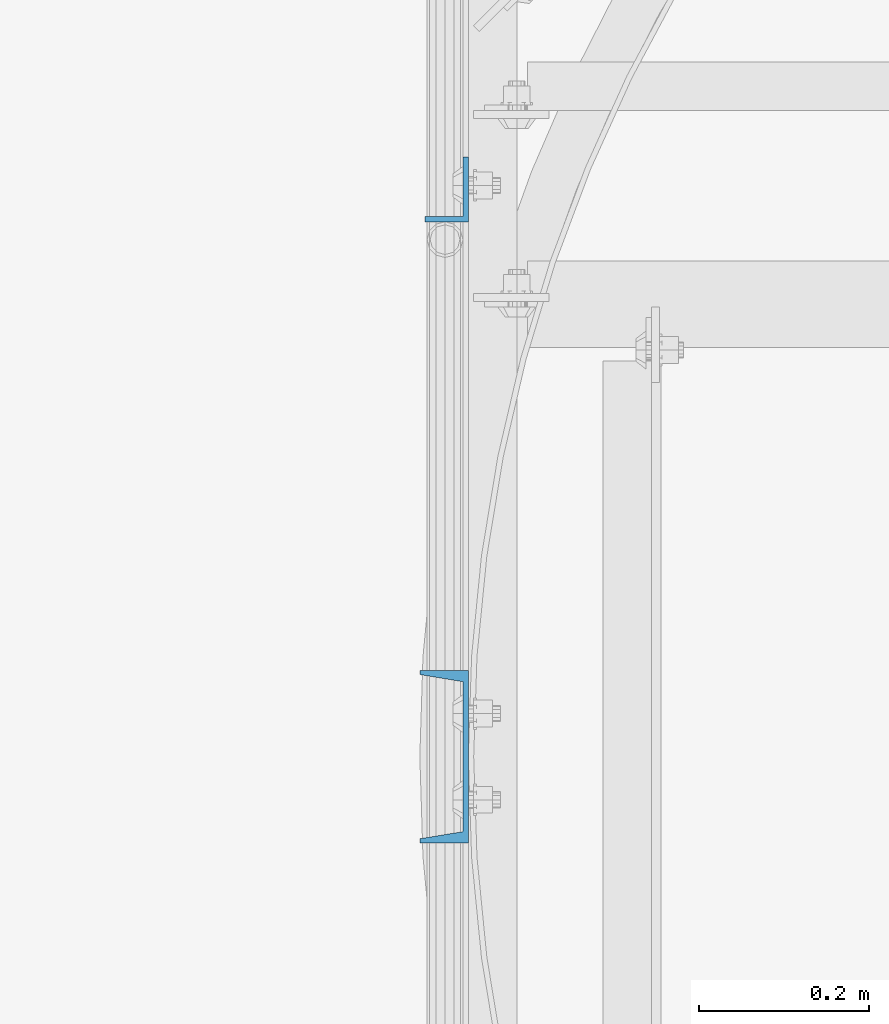
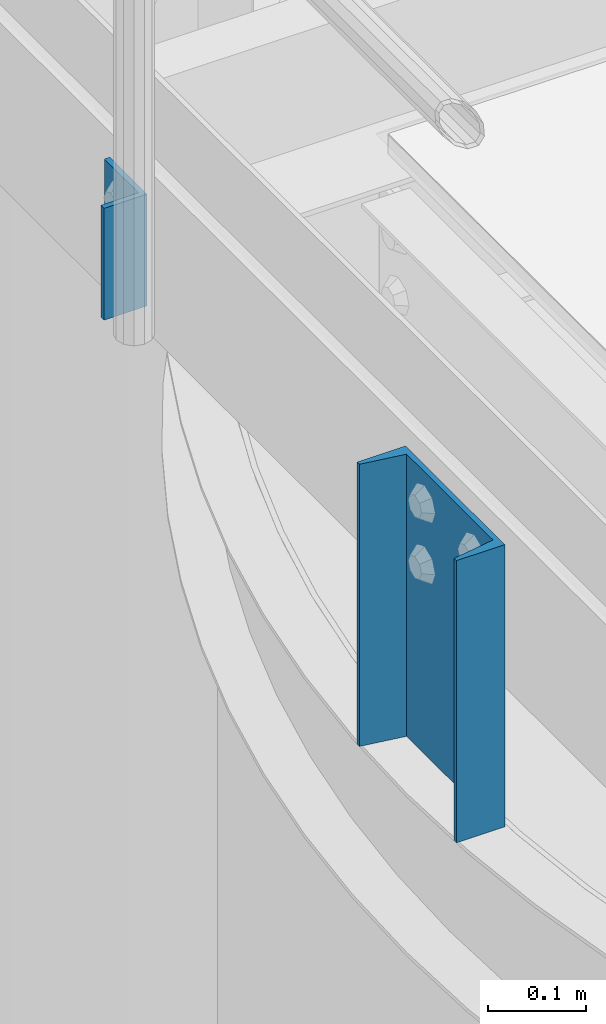
# One storey, part 784 of 1876: 2 columns, 2 elements without a shape of their own.
"""IFC2X3 building model written with IfcOpenShell, lengths in millimetres."""

import ifcopenshell
import ifcopenshell.guid

model = None  # the IFC model being written
_history = None  # IfcOwnerHistory: only IFC2X3 demands one
_inside = {}  # id of a spatial element -> (the spatial element, [elements in it])
_under = {}  # id of a project, library or spatial element -> (it, [spatial elements below it])
_declared = {}  # id of a project -> (the project, [libraries it declares])
_typed = {}  # id of a type object -> (the type object, [elements of that type])
_made_of = {}  # id of a material, layer set ... -> (it, [elements and type objects made of it])


def new_model(schema):
    """Start an empty IFC model of exactly this schema.

    Asked for "IFC4X3", IfcOpenShell would pick the latest addendum, in which some entities
    have other attributes; the version numbers below select the first issue.
    IFC2X3 requires an IfcOwnerHistory on every rooted entity: one is made here for all.
    """
    global model, _history
    if schema == "IFC4X3":
        model = ifcopenshell.file(schema_version=(4, 3, 0, 0))
    else:
        model = ifcopenshell.file(schema=schema)
    _inside.clear()
    _under.clear()
    _declared.clear()
    _typed.clear()
    _made_of.clear()
    _history = None
    if model.schema == "IFC2X3":
        org = make("IfcOrganization", Name="unknown")
        user = make(
            "IfcPersonAndOrganization",
            ThePerson=make("IfcPerson", FamilyName="unknown"),
            TheOrganization=org,
        )
        app = make(
            "IfcApplication",
            ApplicationDeveloper=org,
            Version="unknown",
            ApplicationFullName="unknown",
            ApplicationIdentifier="unknown",
        )
        _history = make(
            "IfcOwnerHistory",
            OwningUser=user,
            OwningApplication=app,
            ChangeAction="ADDED",
            CreationDate=0,
        )
    return model


def make(cls, **values):
    """One entity of the class cls with the attributes given. An attribute that is None is left unset."""
    return model.create_entity(
        cls, **{name: value for name, value in values.items() if value is not None}
    )


def rooted(cls, **values):
    """An entity with a GlobalId (a new one), such as an element, a storey or a relation."""
    return make(cls, GlobalId=ifcopenshell.guid.new(), OwnerHistory=_history, **values)


def si_unit(unit_type, name, prefix=None):
    """IfcSIUnit, for example si_unit("LENGTHUNIT", "METRE", prefix="MILLI")."""
    return make("IfcSIUnit", UnitType=unit_type, Prefix=prefix, Name=name)


def assignment(units):
    """IfcUnitAssignment: the units of a project."""
    return None if units is None else make("IfcUnitAssignment", Units=units)


def point(xyz):
    """IfcCartesianPoint."""
    return None if xyz is None else make("IfcCartesianPoint", Coordinates=xyz)


def direction(xyz):
    """IfcDirection."""
    return None if xyz is None else make("IfcDirection", DirectionRatios=xyz)


def frame(location, z_axis=None, x_axis=None):
    """IfcAxis2Placement3D, a coordinate frame: its origin and axes. An axis left out is left unset."""
    return make(
        "IfcAxis2Placement3D",
        Location=point(location),
        Axis=direction(z_axis),
        RefDirection=direction(x_axis),
    )


def origin_with_axes():
    """The frame at (0, 0, 0) with the z axis (0, 0, 1) and the x axis (1, 0, 0) written out."""
    return frame((0.0, 0.0, 0.0), z_axis=(0.0, 0.0, 1.0), x_axis=(1.0, 0.0, 0.0))


def place(relative_to, where):
    """IfcLocalPlacement: puts the frame where relative to a parent placement (None: the world)."""
    return make(
        "IfcLocalPlacement", PlacementRelTo=relative_to, RelativePlacement=where
    )


def context(
    kind, dimensions, precision=None, world=None, true_north=None, identifier=None
):
    """IfcGeometricRepresentationContext, for example the 3D "Model" context."""
    return make(
        "IfcGeometricRepresentationContext",
        ContextIdentifier=identifier,
        ContextType=kind,
        CoordinateSpaceDimension=dimensions,
        Precision=precision,
        WorldCoordinateSystem=world,
        TrueNorth=true_north,
    )


def subcontext(parent, identifier, kind, view, scale=None):
    """IfcGeometricRepresentationSubContext, for example "Body" below "Model"."""
    return make(
        "IfcGeometricRepresentationSubContext",
        ContextIdentifier=identifier,
        ContextType=kind,
        ParentContext=parent,
        TargetScale=scale,
        TargetView=view,
    )


def project(units=None, contexts=None):
    """IfcProject with its units and contexts."""
    return rooted(
        "IfcProject",
        Name="project",
        RepresentationContexts=contexts,
        UnitsInContext=assignment(units),
    )


def spatial(cls, under=None, at=None, **own):
    """A site, building, storey or space (cls), placed at a placement, below another one or the project."""
    s = rooted(cls, ObjectPlacement=at, **own)
    if under is not None:
        _under.setdefault(under.id(), (under, []))[1].append(s)
    return s


def faces_of(points, faces, orient=None, outer=None):
    """IfcFace entities. A face is a list of loops; a loop is a list of indices into points, from 0.

    orient and outer hold one flag for each loop. By default every Orientation is true, the
    first loop of a face is its IfcFaceOuterBound and the others are IfcFaceBound.
    """
    made = []
    for i, loops in enumerate(faces):
        bounds = []
        for j, loop in enumerate(loops):
            is_outer = j == 0 if outer is None else outer[i][j]
            bounds.append(
                make(
                    "IfcFaceOuterBound" if is_outer else "IfcFaceBound",
                    Bound=make("IfcPolyLoop", Polygon=[points[k] for k in loop]),
                    Orientation=True if orient is None else orient[i][j],
                )
            )
        made.append(make("IfcFace", Bounds=bounds))
    return made


def faceted_brep(points, faces, orient=None, outer=None, voids=None):
    """IfcFacetedBrep: a solid bounded by flat faces; with voids (closed shells), ...WithVoids."""
    shared = [point(p) for p in points]
    hull = make("IfcClosedShell", CfsFaces=faces_of(shared, faces, orient, outer))
    if voids is None:
        return make("IfcFacetedBrep", Outer=hull)
    return make(
        "IfcFacetedBrepWithVoids",
        Outer=hull,
        Voids=[
            make(cls, CfsFaces=faces_of(shared, fs, o, b)) for cls, fs, o, b in voids
        ],
    )


def shape(context_of_items, identifier, shape_type, items):
    """IfcShapeRepresentation: the items that make up one representation, for example the "Body"."""
    return make(
        "IfcShapeRepresentation",
        ContextOfItems=context_of_items,
        RepresentationIdentifier=identifier,
        RepresentationType=shape_type,
        Items=items,
    )


def material(Name=None, Category=None):
    """IfcMaterial."""
    return make("IfcMaterial", Name=Name, Category=Category)


def made_of(thing, what):
    """Note that an element or type object is made of a material, layer set ...; save() writes the relation."""
    if what is not None:
        _made_of.setdefault(what.id(), (what, []))[1].append(thing)
    return thing


def type_object(cls, material=None, **own):
    """A type object (cls), such as IfcWallType, which elements share."""
    return made_of(rooted(cls, **own), material)


def element(
    cls,
    number,
    at=None,
    inside=None,
    cuts=None,
    type_object=None,
    material=None,
    context=None,
    identifier="Body",
    shape_type=None,
    held_by="IfcProductDefinitionShape",
    body=None,
    shapes=None,
    **own,
):
    """One element of the class cls, such as IfcWall. Its Tag is "e" and its number.

    at: its placement. inside: the storey or other place that contains it. cuts: it is an
    opening in that element (IfcRelVoidsElement). A single representation is given by context,
    identifier, shape_type and body (its items); several are given by shapes. held_by: the class
    of the entity that holds the representations. save() writes the other relations.
    """
    e = rooted(cls, Tag="e%d" % number, ObjectPlacement=at, **own)
    if body is not None:
        shapes = [shape(context, identifier, shape_type, body)]
    if shapes is not None:
        e.Representation = make(held_by, Representations=shapes)
    if inside is not None:
        _inside.setdefault(inside.id(), (inside, []))[1].append(e)
    if cuts is not None:
        rooted(
            "IfcRelVoidsElement", RelatingBuildingElement=cuts, RelatedOpeningElement=e
        )
    if type_object is not None:
        _typed.setdefault(type_object.id(), (type_object, []))[1].append(e)
    return made_of(e, material)


def aggregate(whole, parts):
    """IfcRelAggregates: a whole, such as a stair, and the parts it consists of."""
    return rooted("IfcRelAggregates", RelatingObject=whole, RelatedObjects=parts)


def save(model, path):
    """Write the relations noted so far, then the file.

    IfcRelAggregates (storeys below a building ...), IfcRelContainedInSpatialStructure (elements
    in a storey), IfcRelDefinesByType, IfcRelAssociatesMaterial and IfcRelDeclares: one each for
    every whole, place, type object, material and project.
    """
    for whole, parts in _under.values():
        aggregate(whole, parts)
    for where, things in _inside.values():
        rooted(
            "IfcRelContainedInSpatialStructure",
            RelatedElements=things,
            RelatingStructure=where,
        )
    for kind, things in _typed.values():
        rooted("IfcRelDefinesByType", RelatedObjects=things, RelatingType=kind)
    for what, things in _made_of.values():
        rooted("IfcRelAssociatesMaterial", RelatedObjects=things, RelatingMaterial=what)
    for by, libraries in _declared.values():
        rooted("IfcRelDeclares", RelatingContext=by, RelatedDefinitions=libraries)
    model.write(path)


model = new_model("IFC2X3")

# Units and contexts
model_context = context("Model", 3, precision=1e-05, world=origin_with_axes())
body_context = subcontext(model_context, "Body", "Model", "MODEL_VIEW")
ifc_project = project(units=[si_unit("LENGTHUNIT", "METRE", prefix="MILLI"), si_unit("AREAUNIT", "SQUARE_METRE"), si_unit("VOLUMEUNIT", "CUBIC_METRE"), si_unit("MASSUNIT", "GRAM", prefix="KILO"), si_unit("TIMEUNIT", "SECOND"), si_unit("PLANEANGLEUNIT", "RADIAN"), si_unit("SOLIDANGLEUNIT", "STERADIAN"), si_unit("THERMODYNAMICTEMPERATUREUNIT", "DEGREE_CELSIUS"), si_unit("LUMINOUSINTENSITYUNIT", "LUMEN")], contexts=[model_context])

# Site, building, storey
site_placement = place(None, origin_with_axes())
site = spatial("IfcSite", under=ifc_project, at=site_placement, CompositionType="ELEMENT")
building_placement = place(site_placement, origin_with_axes())
building = spatial("IfcBuilding", under=site, at=building_placement, Name="Undefined", CompositionType="ELEMENT")
storey_placement = place(building_placement, origin_with_axes())
storey = spatial("IfcBuildingStorey", under=building, at=storey_placement, Name="Undefined", CompositionType="ELEMENT", Elevation=0.0)

# Assembly, column
assembly_1_placement = place(storey_placement, origin_with_axes())
assembly_1 = element("IfcElementAssembly", 1, at=assembly_1_placement, inside=storey, Name="HANDRAIL", AssemblyPlace="NOTDEFINED", PredefinedType="RIGID_FRAME")
ifc_material = material(Name="STEEL/A36")
column_type_1 = type_object("IfcColumnType", Name="L3X2X1/4", PredefinedType="NOTDEFINED")
column_1_placement = place(assembly_1_placement, frame((3340.10143150122, -12920.1824042969, 7826.375), z_axis=(0.0, 1.0, 0.0), x_axis=(0.0, 0.0, 1.0)))
column_1 = element("IfcColumn", 2, at=column_1_placement, type_object=column_type_1, material=ifc_material, Name="ANGLE", ObjectType="L3X2X1/4", context=body_context, shape_type="Brep", body=[
    faceted_brep([(0.0, 25.3999999999996, -38.1000000000004), (0.0, 25.3999999999996, 38.1000000000004), (139.7, 25.3999999999996, 38.1000000000004), (139.7, 25.3999999999996, -38.1000000000004), (0.0, 19.0500000000002, 38.1000000000004), (139.7, 19.0500000000002, 38.1000000000004), (0.0, 19.0500000000002, -31.75), (139.7, 19.0500000000002, -31.75), (0.0, -25.3999999999996, -31.75), (139.7, -25.3999999999996, -31.75), (0.0, -25.3999999999996, -38.1000000000004), (139.7, -25.3999999999996, -38.1000000000004)], [[[0, 1, 2, 3]], [[1, 4, 5, 2]], [[4, 6, 7, 5]], [[6, 8, 9, 7]], [[8, 10, 11, 9]], [[10, 0, 3, 11]], [[5, 7, 9, 11, 3, 2]], [[10, 8, 6, 4, 1, 0]]]),
])
aggregate(assembly_1, [column_1])

assembly_2_placement = place(storey_placement, origin_with_axes())
assembly_2 = element("IfcElementAssembly", 3, at=assembly_2_placement, inside=storey, Name="BEAM", AssemblyPlace="NOTDEFINED", PredefinedType="RIGID_FRAME")
column_type_2 = type_object("IfcColumnType", Name="C8X11.5", PredefinedType="NOTDEFINED")
column_2_placement = place(assembly_2_placement, frame((3336.92643150122, -13588.9644287103, 7620.01566278096), z_axis=(0.0, 1.0, 0.0), x_axis=(0.0, 0.0, 1.0)))
column_2 = element("IfcColumn", 4, at=column_2_placement, type_object=column_type_2, material=ifc_material, Name="BEAM", ObjectType="C8X11.5", context=body_context, shape_type="Brep", body=[
    faceted_brep([(0.0, 28.5749999999998, -101.6), (0.0, 28.5749999999998, 101.6), (352.425, 28.5749999999998, 101.6), (352.425, 28.5749999999998, -101.6), (0.0, -28.5749999999998, 101.6), (352.425, -28.5749999999998, 101.6), (0.0, -28.5749999999998, 96.8355950000005), (352.425, -28.5749999999998, 96.8355950000005), (0.0, 22.2250000000004, 88.3723150000005), (352.425, 22.2250000000004, 88.3723150000005), (0.0, 22.2250000000004, -88.3723150000005), (352.425, 22.2250000000004, -88.3723150000005), (0.0, -28.5749999999998, -96.8355950000005), (352.425, -28.5749999999998, -96.8355950000005), (0.0, -28.5749999999998, -101.6), (352.425, -28.5749999999998, -101.6)], [[[0, 1, 2, 3]], [[1, 4, 5, 2]], [[4, 6, 7, 5]], [[6, 8, 9, 7]], [[8, 10, 11, 9]], [[10, 12, 13, 11]], [[12, 14, 15, 13]], [[14, 0, 3, 15]], [[5, 7, 9, 11, 13, 15, 3, 2]], [[14, 12, 10, 8, 6, 4, 1, 0]]]),
])
aggregate(assembly_2, [column_2])

save(model, "model.ifc")
